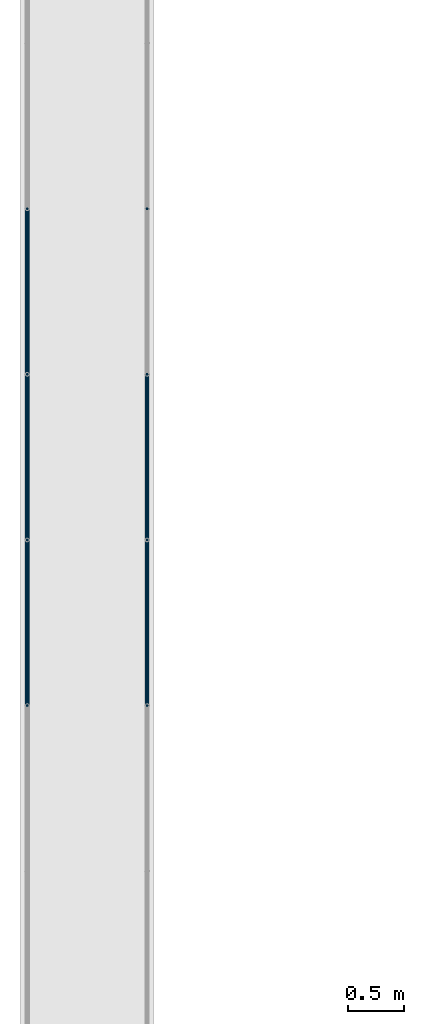
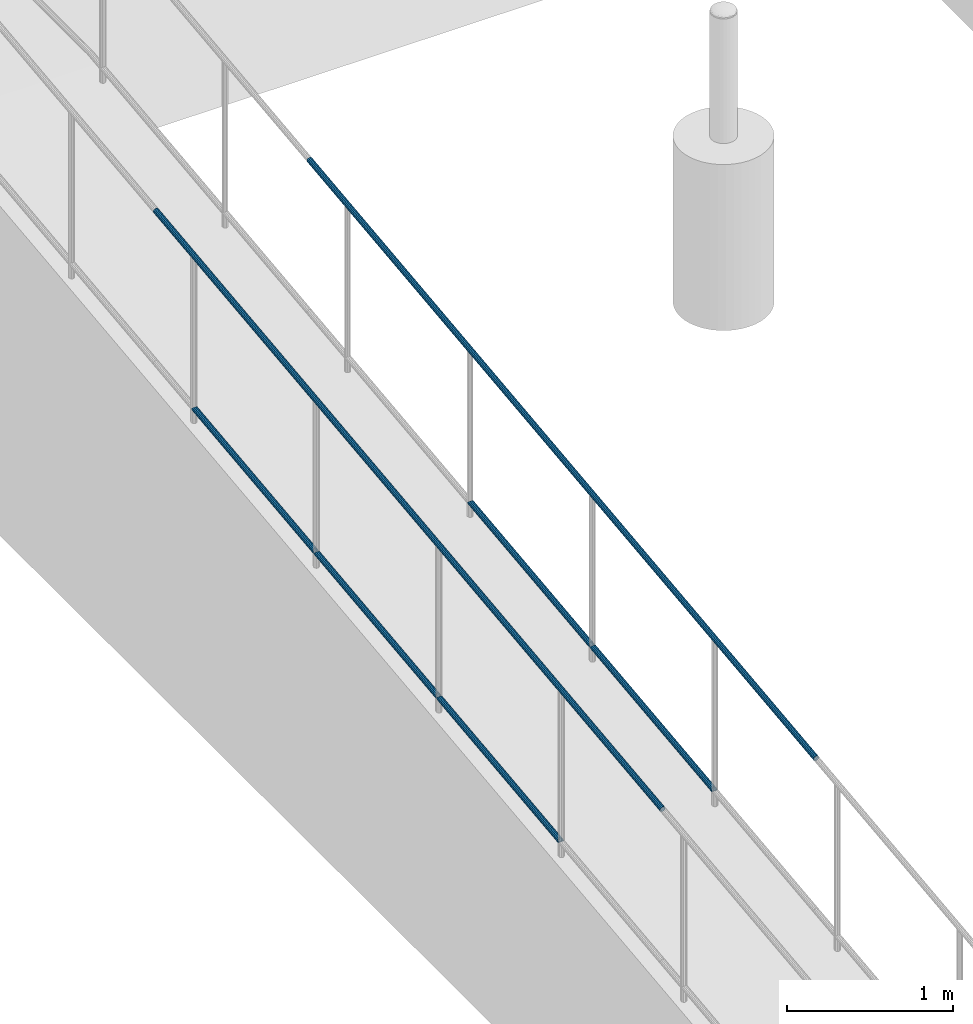
# One storey, part 1042 of 1763: 7 beams, 2 elements without a shape of their own.
"""IFC2X3 building model written with IfcOpenShell, lengths in millimetres."""

from ifc_helpers import new_model, si_unit, frame, origin_with_axes, place, context, subcontext, project, spatial, faceted_brep, material, type_object, element, aggregate, save


model = new_model("IFC2X3")

# Units and contexts
model_context = context("Model", 3, precision=1e-05, world=origin_with_axes())
body_context = subcontext(model_context, "Body", "Model", "MODEL_VIEW")
ifc_project = project(units=[si_unit("LENGTHUNIT", "METRE", prefix="MILLI"), si_unit("AREAUNIT", "SQUARE_METRE"), si_unit("VOLUMEUNIT", "CUBIC_METRE"), si_unit("MASSUNIT", "GRAM", prefix="KILO"), si_unit("TIMEUNIT", "SECOND"), si_unit("PLANEANGLEUNIT", "RADIAN"), si_unit("SOLIDANGLEUNIT", "STERADIAN"), si_unit("THERMODYNAMICTEMPERATUREUNIT", "DEGREE_CELSIUS"), si_unit("LUMINOUSINTENSITYUNIT", "LUMEN")], contexts=[model_context])

# Site, building, storey
site_placement = place(None, origin_with_axes())
site = spatial("IfcSite", under=ifc_project, at=site_placement, CompositionType="ELEMENT")
building_placement = place(site_placement, origin_with_axes())
building = spatial("IfcBuilding", under=site, at=building_placement, Name="Undefined", CompositionType="ELEMENT")
storey_placement = place(building_placement, origin_with_axes())
storey = spatial("IfcBuildingStorey", under=building, at=storey_placement, Name="Undefined", CompositionType="ELEMENT", Elevation=0.0)

# Assembly, beams
assembly_1_placement = place(storey_placement, origin_with_axes())
assembly_1 = element("IfcElementAssembly", 1, at=assembly_1_placement, inside=storey, Name="GUARDRAIL", AssemblyPlace="NOTDEFINED", PredefinedType="RIGID_FRAME")
ifc_material = material(Name="STEEL/A513")
beam_type = type_object("IfcBeamType", PredefinedType="NOTDEFINED")
beam_1_placement = place(assembly_1_placement, frame((-97200.6527017878, 1949.23787684902, 5506.99410694077), z_axis=(0.0, -0.114062593029902, 0.993473565260443), x_axis=(0.0, 0.993473565260443, 0.114062593029902)))
beam_1 = element("IfcBeam", 2, at=beam_1_placement, type_object=beam_type, material=ifc_material, Name="GUARDRAIL", context=body_context, shape_type="Brep", body=[
    faceted_brep([(1468.16675315117, -9.52499999999418, 16.4977839425374), (1467.58910193435, -9.52499999999418, 11.4667123803993), (1467.30386676072, -7.68349999999919, 13.3082123803997), (1465.46793646955, 0.0, 15.3670000004431), (1465.89080650931, 0.0, 19.0500000004431), (1467.30386676072, 7.68349999999919, 13.3082123803997), (1467.58910193435, 9.52499999999418, 11.4667123803993), (1468.16675315117, 9.52499999999418, 16.4977839425374), (1482.87870351455, 19.0500000000029, 4.47471393272281e-10), (1474.38475501203, 16.4977839420899, 9.52500000044529), (1472.19749618567, 16.4977839420899, -9.52499999955671), (1470.96279339167, 13.3082123799541, 7.68350000044484), (1472.15291256472, 15.3669999999984, 4.43833414465189e-10), (1469.19840460508, 13.3082123799541, -7.68349999955717), (1464.95596095143, 9.52499999999418, -11.4667123795143), (1464.37830973461, 9.52499999999418, -16.4977839416533), (1464.24785573805, 7.68349999999919, -13.3082123795139), (1461.93915889636, 0.0, -15.3669999995591), (1461.5162888566, 0.0, -19.04999999956), (1464.95596095143, -9.52499999999418, -11.4667123795143), (1464.37830973461, -9.52499999999418, -16.4977839416533), (1464.24785573805, -7.68349999999919, -13.3082123795139), (1482.87870351475, -19.0500000000029, 4.2564352042973e-10), (1472.19749618567, -16.4977839420899, -9.52499999955671), (1474.38475501203, -16.4977839420899, 9.52500000044529), (1469.19840460508, -13.3082123799541, -7.68349999955717), (1472.15291256472, -15.3669999999984, 4.43833414465189e-10), (1470.96279339167, -13.3082123799541, 7.68350000044484), (8.49524500772077, -16.4977839420899, -9.52499999999782), (14.7132496349991, -9.52499999999418, -16.4977839420899), (0.00129272617550669, 19.0500000000029, 0.0), (8.49524500772077, 16.4977839420899, -9.52499999999782), (10.6824953029745, 16.4977839420899, 9.52500000000418), (18.5016782752491, 9.52499999999418, 16.4977839421008), (21.3636978799404, 0.0, 19.0500000000075), (14.7132496349991, 9.52499999999418, -16.4977839420899), (16.989197289432, 0.0, -19.0499999999956), (17.4120656798477, 0.0, -15.3669999999956), (15.2908985987647, -9.52499999999418, -11.4667123799509), (15.5761345719984, -7.68349999999919, -13.3082123799513), (15.5761345719984, 7.68349999999919, -13.3082123799513), (15.2908985987647, 9.52499999999418, -11.4667123799509), (11.9172056406151, 13.3082123799541, -7.68349999999737), (10.7270831318519, 15.3669999999984, 4.54747350886464e-12), (13.6815875454467, 13.3082123799541, 7.68350000000555), (17.9240293114835, 9.52499999999418, 11.4667123799618), (18.6321336751216, 7.68349999999919, 13.3082123799622), (20.9408294895247, 0.0, 15.3670000000075), (18.6321336751212, -7.68349999999919, 13.3082123799622), (17.9240293114835, -9.52499999999418, 11.4667123799618), (18.5016782752491, -9.52499999999418, 16.4977839421008), (10.6824953029745, -16.4977839420899, 9.52500000000418), (0.00129272617550669, -19.0500000000029, 0.0), (13.6815875454458, -13.3082123799541, 7.68350000000464), (10.7270831318501, -15.3669999999984, 3.63797880709171e-12), (11.9172056406137, -13.3082123799541, -7.68349999999646)], [[[0, 1, 2, 3, 4]], [[4, 3, 5, 6, 7]], [[8, 9, 10]], [[7, 6, 11, 12, 13, 14, 15, 10, 9]], [[16, 17, 18, 15, 14]], [[19, 20, 18, 17, 21]], [[22, 23, 24]], [[24, 23, 20, 19, 25, 26, 27, 1, 0]], [[28, 29, 20, 23]], [[30, 31, 32]], [[33, 34, 4, 7]], [[32, 33, 7, 9]], [[30, 32, 9, 8]], [[31, 30, 8, 10]], [[35, 31, 10, 15]], [[36, 35, 15, 18]], [[29, 36, 18, 20]], [[37, 36, 29, 38, 39]], [[40, 41, 35, 36, 37]], [[32, 31, 35, 41, 42, 43, 44, 45, 33]], [[33, 45, 46, 47, 34]], [[34, 47, 48, 49, 50]], [[34, 50, 0, 4]], [[50, 51, 24, 0]], [[51, 52, 22, 24]], [[52, 28, 23, 22]], [[51, 28, 52]], [[50, 49, 53, 54, 55, 38, 29, 28, 51]], [[55, 54, 26, 25]], [[21, 39, 38, 55, 25, 19]], [[37, 39, 21, 17]], [[40, 37, 17, 16]], [[42, 41, 40, 16, 14, 13]], [[43, 42, 13, 12]], [[44, 43, 12, 11]], [[5, 46, 45, 44, 11, 6]], [[47, 46, 5, 3]], [[48, 47, 3, 2]], [[53, 49, 48, 2, 1, 27]], [[54, 53, 27, 26]]]),
])
beam_2_placement = place(assembly_1_placement, frame((-97200.6527017878, 476.037883341376, 5337.85320859481), z_axis=(0.0, -0.114062593029902, 0.993473565260443), x_axis=(0.0, 0.993473565260443, 0.114062593029902)))
beam_2 = element("IfcBeam", 3, at=beam_2_placement, type_object=beam_type, material=ifc_material, Name="GUARDRAIL", context=body_context, shape_type="Brep", body=[
    faceted_brep([(1468.16723516158, -9.52499999999418, 16.4977839425464), (1467.58958619782, -9.52499999999418, 11.4667123804093), (1467.3043502247, -7.68349999999919, 13.3082123804079), (1465.46841911673, 0.0, 15.3670000004531), (1465.89128750715, 0.0, 19.0500000004522), (1467.3043502247, 7.68349999999919, 13.3082123804079), (1467.58958619782, 9.52499999999418, 11.4667123804093), (1468.16723516158, 9.52499999999418, 16.4977839425464), (1482.87919207074, 19.0500000000029, 4.57475834991783e-10), (1474.38523978886, 16.4977839420899, 9.52500000045529), (1472.19798949361, 16.4977839420899, -9.52499999954671), (1470.96327915608, 13.3082123799541, 7.68350000045393), (1472.15340166484, 15.3669999999984, 4.53837856184691e-10), (1469.19889725125, 13.3082123799541, -7.68349999954717), (1464.9564554851, 9.52499999999418, -11.4667123795043), (1464.37880652133, 9.52499999999418, -16.4977839416424), (1464.24835112158, 7.68349999999919, -13.3082123795048), (1461.93965530706, 0.0, -15.36699999955), (1461.51678691664, 0.0, -19.04999999955), (1464.9564554851, -9.52499999999418, -11.4667123795043), (1464.37880652133, -9.52499999999418, -16.4977839416424), (1464.24835112157, -7.68349999999919, -13.3082123795048), (1482.87919207057, -19.0500000000029, 4.76575223729014e-10), (1472.19798949361, -16.4977839420899, -9.52499999954671), (1474.38523978886, -16.4977839420899, 9.52500000045529), (1469.19889725125, -13.3082123799541, -7.68349999954717), (1472.15340166484, -15.3669999999984, 4.53837856184691e-10), (1470.96327915608, -13.3082123799541, 7.68350000045393), (8.49463121237, -16.4977839420899, -9.52499999999782), (14.7126324911599, -9.52499999999418, -16.4977839420899), (0.00068350478454704, 19.0500000000029, 0.0), (8.49463121237, 16.4977839420899, -9.52499999999782), (10.6818918337324, 16.4977839420899, 9.52500000000418), (18.5010790167537, 9.52499999999418, 16.4977839421008), (21.3631001626848, 0.0, 19.0500000000075), (14.7126324911599, 9.52499999999418, -16.4977839420899), (16.9885789199607, 0.0, -19.0499999999956), (17.4114493067575, 0.0, -15.3669999999956), (15.2902841820321, -9.52499999999418, -11.4667123799509), (15.575519187561, -7.68349999999919, -13.3082123799513), (15.575519187561, 7.68349999999919, -13.3082123799513), (15.2902841820321, 9.52499999999418, -11.4667123799509), (11.9165930406441, 13.3082123799541, -7.68349999999646), (10.7264745694495, 15.3669999999984, 4.54747350886464e-12), (13.6809832752053, 13.3082123799541, 7.68350000000555), (17.923427325881, 9.52499999999418, 11.4667123799609), (18.631532718199, 7.68349999999919, 13.3082123799622), (20.9402297758882, 0.0, 15.3670000000075), (18.631532718199, -7.68349999999919, 13.3082123799622), (17.923427325881, -9.52499999999418, 11.4667123799609), (18.5010790167537, -9.52499999999418, 16.4977839421008), (10.6818918337324, -16.4977839420899, 9.52500000000418), (0.00068350478454704, -19.0500000000029, 0.0), (13.6809832752053, -13.3082123799541, 7.68350000000555), (10.7264745694495, -15.3669999999984, 4.54747350886464e-12), (11.9165930406441, -13.3082123799541, -7.68349999999646)], [[[0, 1, 2, 3, 4]], [[4, 3, 5, 6, 7]], [[8, 9, 10]], [[7, 6, 11, 12, 13, 14, 15, 10, 9]], [[16, 17, 18, 15, 14]], [[19, 20, 18, 17, 21]], [[22, 23, 24]], [[24, 23, 20, 19, 25, 26, 27, 1, 0]], [[28, 29, 20, 23]], [[30, 31, 32]], [[33, 34, 4, 7]], [[32, 33, 7, 9]], [[30, 32, 9, 8]], [[31, 30, 8, 10]], [[35, 31, 10, 15]], [[36, 35, 15, 18]], [[29, 36, 18, 20]], [[37, 36, 29, 38, 39]], [[40, 41, 35, 36, 37]], [[32, 31, 35, 41, 42, 43, 44, 45, 33]], [[33, 45, 46, 47, 34]], [[34, 47, 48, 49, 50]], [[34, 50, 0, 4]], [[50, 51, 24, 0]], [[51, 52, 22, 24]], [[52, 28, 23, 22]], [[51, 28, 52]], [[50, 49, 53, 54, 55, 38, 29, 28, 51]], [[55, 54, 26, 25]], [[21, 39, 38, 55, 25, 19]], [[37, 39, 21, 17]], [[40, 37, 17, 16]], [[42, 41, 40, 16, 14, 13]], [[43, 42, 13, 12]], [[44, 43, 12, 11]], [[5, 46, 45, 44, 11, 6]], [[47, 46, 5, 3]], [[48, 47, 3, 2]], [[53, 49, 48, 2, 1, 27]], [[54, 53, 27, 26]]]),
])
beam_3_placement = place(assembly_1_placement, frame((-97200.6527017878, -997.16211813846, 5168.71230933354), z_axis=(0.0, -0.114062593029902, 0.993473565260443), x_axis=(0.0, 0.993473565260443, 0.114062593029902)))
beam_3 = element("IfcBeam", 4, at=beam_3_placement, type_object=beam_type, material=ifc_material, Name="GUARDRAIL", context=body_context, shape_type="Brep", body=[
    faceted_brep([(1468.16665642951, -9.52499999999418, 16.4977839425555), (1467.58900470802, -9.52499999999418, 11.4667123804174), (1467.30376971339, -7.68349999999919, 13.3082123804179), (1465.46783960526, 0.0, 15.3670000004613), (1465.89071001447, 0.0, 19.0500000004622), (1467.3037697134, 7.68349999999919, 13.308212380417), (1467.58900470802, 9.52499999999418, 11.4667123804174), (1468.16665642951, 9.52499999999418, 16.4977839425555), (1482.87860532686, 19.0500000000029, 4.66570782009512e-10), (1474.38465767071, 16.4977839420899, 9.52500000046439), (1472.19739693342, 16.4977839420899, -9.52499999953761), (1470.96269582906, 13.3082123799541, 7.68350000046303), (1472.15281425492, 15.3669999999984, 4.6293280320242e-10), (1469.19830550098, 13.3082123799541, -7.68349999953807), (1464.95586142462, 9.52499999999418, -11.4667123794952), (1464.37820970313, 9.52499999999418, -16.4977839416342), (1464.24775602078, 7.68349999999919, -13.3082123794957), (1461.9390589491, 0.0, -15.3669999995409), (1461.51618853989, 0.0, -19.0499999995409), (1464.95586142462, -9.52499999999418, -11.4667123794952), (1464.37820970313, -9.52499999999418, -16.4977839416342), (1464.24775602078, -7.68349999999919, -13.3082123794948), (1482.87860532695, -19.0500000000029, 4.55656845588237e-10), (1472.19739693342, -16.4977839420899, -9.52499999953761), (1474.38465767071, -16.4977839420899, 9.52500000046439), (1469.19830550097, -13.3082123799541, -7.68349999953807), (1472.15281425491, -15.3669999999984, 4.6293280320242e-10), (1470.96269582905, -13.3082123799541, 7.68350000046303), (8.49463121237, -16.4977839420899, -9.52499999999782), (14.7126324911599, -9.52499999999418, -16.4977839420899), (0.00068350478454704, 19.0500000000029, 0.0), (8.49463121237, 16.4977839420899, -9.52499999999782), (10.6818918337324, 16.4977839420899, 9.52500000000418), (18.5010790167537, 9.52499999999418, 16.4977839421008), (21.3631001626848, 0.0, 19.0500000000075), (14.7126324911599, 9.52499999999418, -16.4977839420899), (16.9885789199607, 0.0, -19.0499999999956), (17.4114493067575, 0.0, -15.3669999999956), (15.2902841820321, -9.52499999999418, -11.4667123799509), (15.575519187561, -7.68349999999919, -13.3082123799513), (15.575519187561, 7.68349999999919, -13.3082123799513), (15.2902841820321, 9.52499999999418, -11.4667123799509), (11.9165930406441, 13.3082123799541, -7.68349999999646), (10.7264745694495, 15.3669999999984, 4.54747350886464e-12), (13.6809832752053, 13.3082123799541, 7.68350000000555), (17.923427325881, 9.52499999999418, 11.4667123799609), (18.631532718199, 7.68349999999919, 13.3082123799622), (20.9402297758882, 0.0, 15.3670000000075), (18.631532718199, -7.68349999999919, 13.3082123799622), (17.923427325881, -9.52499999999418, 11.4667123799609), (18.5010790167537, -9.52499999999418, 16.4977839421008), (10.6818918337324, -16.4977839420899, 9.52500000000418), (0.00068350478454704, -19.0500000000029, 0.0), (13.6809832752053, -13.3082123799541, 7.68350000000555), (10.7264745694495, -15.3669999999984, 4.54747350886464e-12), (11.9165930406441, -13.3082123799541, -7.68349999999646)], [[[0, 1, 2, 3, 4]], [[4, 3, 5, 6, 7]], [[8, 9, 10]], [[7, 6, 11, 12, 13, 14, 15, 10, 9]], [[16, 17, 18, 15, 14]], [[19, 20, 18, 17, 21]], [[22, 23, 24]], [[24, 23, 20, 19, 25, 26, 27, 1, 0]], [[28, 29, 20, 23]], [[30, 31, 32]], [[33, 34, 4, 7]], [[32, 33, 7, 9]], [[30, 32, 9, 8]], [[31, 30, 8, 10]], [[35, 31, 10, 15]], [[36, 35, 15, 18]], [[29, 36, 18, 20]], [[37, 36, 29, 38, 39]], [[40, 41, 35, 36, 37]], [[32, 31, 35, 41, 42, 43, 44, 45, 33]], [[33, 45, 46, 47, 34]], [[34, 47, 48, 49, 50]], [[34, 50, 0, 4]], [[50, 51, 24, 0]], [[51, 52, 22, 24]], [[52, 28, 23, 22]], [[51, 28, 52]], [[50, 49, 53, 54, 55, 38, 29, 28, 51]], [[55, 54, 26, 25]], [[21, 39, 38, 55, 25, 19]], [[37, 39, 21, 17]], [[40, 37, 17, 16]], [[42, 41, 40, 16, 14, 13]], [[43, 42, 13, 12]], [[44, 43, 12, 11]], [[5, 46, 45, 44, 11, 6]], [[47, 46, 5, 3]], [[48, 47, 3, 2]], [[53, 49, 48, 2, 1, 27]], [[54, 53, 27, 26]]]),
])
beam_4_placement = place(assembly_1_placement, frame((-97200.6527017878, -2216.29390356327, 6146.34146606881), z_axis=(-1.0, 0.0, 0.0), x_axis=(0.0, 0.993473565260443, 0.114062593029902)))
beam_4 = element("IfcBeam", 5, at=beam_4_placement, type_object=beam_type, material=ifc_material, Name="GUARDRAIL", context=body_context, shape_type="Brep", body=[
    faceted_brep([(4.71409293822944e-08, -15.3669999999984, 0.0), (-1.81898940354586e-12, -13.3082123799541, 7.68349999999919), (6136.046507088, -13.3082123818076, 7.68349999999919), (6136.046507088, -15.3670000018528, 0.0), (-3.63797880709171e-12, -7.68349999999919, 13.3082123799531), (6136.046507088, -7.68350000185274, 13.3082123799541), (-1.81898940354586e-12, 0.0, 15.3669999999966), (6136.046507088, -1.85082171810791e-09, 15.3669999999984), (-3.63797880709171e-12, 7.68349999999919, 13.3082123799531), (6136.046507088, 7.68349999814836, 13.3082123799541), (-1.81898940354586e-12, 13.3082123799541, 7.68349999999919), (6136.046507088, 13.3082123781051, 7.68349999999919), (4.71409293822944e-08, 15.3669999999984, 0.0), (6136.046507088, 15.3669999981494, 0.0), (3.63797880709171e-12, 13.3082123799541, -7.68349999999737), (6136.046507088, 13.3082123781051, -7.68349999999919), (3.63797880709171e-12, 7.68349999999919, -13.3082123799522), (6136.046507088, 7.68349999814836, -13.3082123799541), (3.63797880709171e-12, 0.0, -15.3669999999956), (6136.046507088, -1.85082171810791e-09, -15.3669999999984), (3.63797880709171e-12, -7.68349999999919, -13.3082123799522), (6136.046507088, -7.68350000185274, -13.3082123799541), (3.63797880709171e-12, -13.3082123799541, -7.68349999999737), (6136.046507088, -13.3082123818076, -7.68349999999919), (0.0, -19.0500000000029, 0.0), (0.0, -16.4977839420899, -9.52500000000146), (6136.046507088, -16.4977839439462, -9.52499999999418), (6136.046507088, -19.0500000018519, 0.0), (0.0, -9.52499999999418, -16.4977839420935), (6136.046507088, -9.52500000185228, -16.4977839420899), (1.45519152283669e-11, 1.81898940354586e-12, -19.0499999999993), (6136.046507088, -1.85082171810791e-09, -19.0500000000029), (0.0, 9.52499999999418, -16.4977839420935), (6136.046507088, 9.5249999981479, -16.4977839420899), (0.0, 16.4977839420899, -9.52500000000146), (6136.046507088, 16.4977839402427, -9.52499999999418), (0.0, 19.0500000000029, 0.0), (6136.046507088, 19.0499999981485, 0.0), (0.0, 16.4977839420899, 9.52500000000146), (6136.046507088, 16.4977839402427, 9.52499999999418), (0.0, 9.52499999999418, 16.4977839420935), (6136.046507088, 9.5249999981479, 16.4977839420899), (1.45519152283669e-11, 1.81898940354586e-12, 19.0499999999993), (6136.046507088, -1.85082171810791e-09, 19.0500000000029), (0.0, -9.52499999999418, 16.4977839420935), (6136.046507088, -9.52500000185228, 16.4977839420899), (0.0, -16.4977839420899, 9.52500000000146), (6136.046507088, -16.4977839439462, 9.52499999999418)], [[[0, 1, 2, 3]], [[1, 4, 5, 2]], [[4, 6, 7, 5]], [[6, 8, 9, 7]], [[8, 10, 11, 9]], [[10, 12, 13, 11]], [[12, 14, 15, 13]], [[14, 16, 17, 15]], [[16, 18, 19, 17]], [[18, 20, 21, 19]], [[20, 22, 23, 21]], [[22, 0, 3, 23]], [[24, 25, 26, 27]], [[25, 28, 29, 26]], [[28, 30, 31, 29]], [[30, 32, 33, 31]], [[32, 34, 35, 33]], [[34, 36, 37, 35]], [[36, 38, 39, 37]], [[38, 40, 41, 39]], [[40, 42, 43, 41]], [[42, 44, 45, 43]], [[44, 46, 47, 45]], [[46, 24, 27, 47]], [[29, 31, 33, 35, 37, 39, 41, 43, 45, 47, 27, 26], [5, 7, 9, 11, 13, 15, 17, 19, 21, 23, 3, 2]], [[46, 44, 42, 40, 38, 36, 34, 32, 30, 28, 25, 24], [22, 20, 18, 16, 14, 12, 10, 8, 6, 4, 1, 0]]]),
])
aggregate(assembly_1, [beam_1, beam_2, beam_3, beam_4])

assembly_2_placement = place(storey_placement, origin_with_axes())
assembly_2 = element("IfcElementAssembly", 6, at=assembly_2_placement, inside=storey, Name="GUARDRAIL", AssemblyPlace="NOTDEFINED", PredefinedType="RIGID_FRAME")
beam_5_placement = place(assembly_2_placement, frame((-96133.8527017878, -2216.29390356327, 6146.34146606881), z_axis=(-1.0, 0.0, 0.0), x_axis=(0.0, 0.993473565260443, 0.114062593029902)))
beam_5 = element("IfcBeam", 7, at=beam_5_placement, type_object=beam_type, material=ifc_material, Name="GUARDRAIL", context=body_context, shape_type="Brep", body=[
    faceted_brep([(4.71409293822944e-08, -15.3669999999984, 0.0), (-1.81898940354586e-12, -13.3082123799541, 7.68349999999919), (6136.046507088, -13.3082123818076, 7.68349999999919), (6136.046507088, -15.3670000018528, 0.0), (-3.63797880709171e-12, -7.68349999999919, 13.3082123799531), (6136.046507088, -7.68350000185274, 13.3082123799541), (-1.81898940354586e-12, 0.0, 15.3669999999966), (6136.046507088, -1.85082171810791e-09, 15.3669999999984), (-3.63797880709171e-12, 7.68349999999919, 13.3082123799531), (6136.046507088, 7.68349999814836, 13.3082123799541), (-1.81898940354586e-12, 13.3082123799541, 7.68349999999919), (6136.046507088, 13.3082123781051, 7.68349999999919), (4.71409293822944e-08, 15.3669999999984, 0.0), (6136.046507088, 15.3669999981494, 0.0), (3.63797880709171e-12, 13.3082123799541, -7.68349999999737), (6136.046507088, 13.3082123781051, -7.68349999999919), (3.63797880709171e-12, 7.68349999999919, -13.3082123799522), (6136.046507088, 7.68349999814836, -13.3082123799541), (3.63797880709171e-12, 0.0, -15.3669999999956), (6136.046507088, -1.85082171810791e-09, -15.3669999999984), (3.63797880709171e-12, -7.68349999999919, -13.3082123799522), (6136.046507088, -7.68350000185274, -13.3082123799541), (3.63797880709171e-12, -13.3082123799541, -7.68349999999737), (6136.046507088, -13.3082123818076, -7.68349999999919), (0.0, -19.0500000000029, 0.0), (0.0, -16.4977839420899, -9.52500000000146), (6136.046507088, -16.4977839439462, -9.52499999999418), (6136.046507088, -19.0500000018519, 0.0), (0.0, -9.52499999999418, -16.4977839420935), (6136.046507088, -9.52500000185228, -16.4977839420899), (1.45519152283669e-11, 1.81898940354586e-12, -19.0499999999993), (6136.046507088, -1.85082171810791e-09, -19.0500000000029), (0.0, 9.52499999999418, -16.4977839420935), (6136.046507088, 9.5249999981479, -16.4977839420899), (0.0, 16.4977839420899, -9.52500000000146), (6136.046507088, 16.4977839402427, -9.52499999999418), (0.0, 19.0500000000029, 0.0), (6136.046507088, 19.0499999981485, 0.0), (0.0, 16.4977839420899, 9.52500000000146), (6136.046507088, 16.4977839402427, 9.52499999999418), (0.0, 9.52499999999418, 16.4977839420935), (6136.046507088, 9.5249999981479, 16.4977839420899), (1.45519152283669e-11, 1.81898940354586e-12, 19.0499999999993), (6136.046507088, -1.85082171810791e-09, 19.0500000000029), (0.0, -9.52499999999418, 16.4977839420935), (6136.046507088, -9.52500000185228, 16.4977839420899), (0.0, -16.4977839420899, 9.52500000000146), (6136.046507088, -16.4977839439462, 9.52499999999418)], [[[0, 1, 2, 3]], [[1, 4, 5, 2]], [[4, 6, 7, 5]], [[6, 8, 9, 7]], [[8, 10, 11, 9]], [[10, 12, 13, 11]], [[12, 14, 15, 13]], [[14, 16, 17, 15]], [[16, 18, 19, 17]], [[18, 20, 21, 19]], [[20, 22, 23, 21]], [[22, 0, 3, 23]], [[24, 25, 26, 27]], [[25, 28, 29, 26]], [[28, 30, 31, 29]], [[30, 32, 33, 31]], [[32, 34, 35, 33]], [[34, 36, 37, 35]], [[36, 38, 39, 37]], [[38, 40, 41, 39]], [[40, 42, 43, 41]], [[42, 44, 45, 43]], [[44, 46, 47, 45]], [[46, 24, 27, 47]], [[29, 31, 33, 35, 37, 39, 41, 43, 45, 47, 27, 26], [5, 7, 9, 11, 13, 15, 17, 19, 21, 23, 3, 2]], [[46, 44, 42, 40, 38, 36, 34, 32, 30, 28, 25, 24], [22, 20, 18, 16, 14, 12, 10, 8, 6, 4, 1, 0]]]),
])
beam_6_placement = place(assembly_2_placement, frame((-96133.8527017878, 476.037883341376, 5337.85320859481), z_axis=(0.0, -0.114062593029902, 0.993473565260443), x_axis=(0.0, 0.993473565260443, 0.114062593029902)))
beam_6 = element("IfcBeam", 8, at=beam_6_placement, type_object=beam_type, material=ifc_material, Name="GUARDRAIL", context=body_context, shape_type="Brep", body=[
    faceted_brep([(1468.16723516158, -9.52499999999418, 16.4977839425464), (1467.58958619782, -9.52499999999418, 11.4667123804093), (1467.3043502247, -7.68349999999919, 13.3082123804079), (1465.46841911673, 0.0, 15.3670000004531), (1465.89128750715, 0.0, 19.0500000004522), (1467.3043502247, 7.68349999999919, 13.3082123804079), (1467.58958619782, 9.52499999999418, 11.4667123804093), (1468.16723516158, 9.52499999999418, 16.4977839425464), (1482.87919207074, 19.0500000000029, 4.57475834991783e-10), (1474.38523978886, 16.4977839420899, 9.52500000045529), (1472.19798949361, 16.4977839420899, -9.52499999954671), (1470.96327915608, 13.3082123799541, 7.68350000045393), (1472.15340166484, 15.3669999999984, 4.53837856184691e-10), (1469.19889725125, 13.3082123799541, -7.68349999954717), (1464.9564554851, 9.52499999999418, -11.4667123795043), (1464.37880652133, 9.52499999999418, -16.4977839416424), (1464.24835112158, 7.68349999999919, -13.3082123795048), (1461.93965530706, 0.0, -15.36699999955), (1461.51678691664, 0.0, -19.04999999955), (1464.9564554851, -9.52499999999418, -11.4667123795043), (1464.37880652133, -9.52499999999418, -16.4977839416424), (1464.24835112157, -7.68349999999919, -13.3082123795048), (1482.87919207057, -19.0500000000029, 4.76575223729014e-10), (1472.19798949361, -16.4977839420899, -9.52499999954671), (1474.38523978886, -16.4977839420899, 9.52500000045529), (1469.19889725125, -13.3082123799541, -7.68349999954717), (1472.15340166484, -15.3669999999984, 4.53837856184691e-10), (1470.96327915608, -13.3082123799541, 7.68350000045393), (8.49463121237, -16.4977839420899, -9.52499999999782), (14.7126324911599, -9.52499999999418, -16.4977839420899), (0.00068350478454704, 19.0500000000029, 0.0), (8.49463121237, 16.4977839420899, -9.52499999999782), (10.6818918337324, 16.4977839420899, 9.52500000000418), (18.5010790167537, 9.52499999999418, 16.4977839421008), (21.3631001626848, 0.0, 19.0500000000075), (14.7126324911599, 9.52499999999418, -16.4977839420899), (16.9885789199607, 0.0, -19.0499999999956), (17.4114493067575, 0.0, -15.3669999999956), (15.2902841820321, -9.52499999999418, -11.4667123799509), (15.575519187561, -7.68349999999919, -13.3082123799513), (15.575519187561, 7.68349999999919, -13.3082123799513), (15.2902841820321, 9.52499999999418, -11.4667123799509), (11.9165930406441, 13.3082123799541, -7.68349999999646), (10.7264745694495, 15.3669999999984, 4.54747350886464e-12), (13.6809832752053, 13.3082123799541, 7.68350000000555), (17.923427325881, 9.52499999999418, 11.4667123799609), (18.631532718199, 7.68349999999919, 13.3082123799622), (20.9402297758882, 0.0, 15.3670000000075), (18.631532718199, -7.68349999999919, 13.3082123799622), (17.923427325881, -9.52499999999418, 11.4667123799609), (18.5010790167537, -9.52499999999418, 16.4977839421008), (10.6818918337324, -16.4977839420899, 9.52500000000418), (0.00068350478454704, -19.0500000000029, 0.0), (13.6809832752053, -13.3082123799541, 7.68350000000555), (10.7264745694495, -15.3669999999984, 4.54747350886464e-12), (11.9165930406441, -13.3082123799541, -7.68349999999646)], [[[0, 1, 2, 3, 4]], [[4, 3, 5, 6, 7]], [[8, 9, 10]], [[7, 6, 11, 12, 13, 14, 15, 10, 9]], [[16, 17, 18, 15, 14]], [[19, 20, 18, 17, 21]], [[22, 23, 24]], [[24, 23, 20, 19, 25, 26, 27, 1, 0]], [[28, 29, 20, 23]], [[30, 31, 32]], [[33, 34, 4, 7]], [[32, 33, 7, 9]], [[30, 32, 9, 8]], [[31, 30, 8, 10]], [[35, 31, 10, 15]], [[36, 35, 15, 18]], [[29, 36, 18, 20]], [[37, 36, 29, 38, 39]], [[40, 41, 35, 36, 37]], [[32, 31, 35, 41, 42, 43, 44, 45, 33]], [[33, 45, 46, 47, 34]], [[34, 47, 48, 49, 50]], [[34, 50, 0, 4]], [[50, 51, 24, 0]], [[51, 52, 22, 24]], [[52, 28, 23, 22]], [[51, 28, 52]], [[50, 49, 53, 54, 55, 38, 29, 28, 51]], [[55, 54, 26, 25]], [[21, 39, 38, 55, 25, 19]], [[37, 39, 21, 17]], [[40, 37, 17, 16]], [[42, 41, 40, 16, 14, 13]], [[43, 42, 13, 12]], [[44, 43, 12, 11]], [[5, 46, 45, 44, 11, 6]], [[47, 46, 5, 3]], [[48, 47, 3, 2]], [[53, 49, 48, 2, 1, 27]], [[54, 53, 27, 26]]]),
])
beam_7_placement = place(assembly_2_placement, frame((-96133.8527017878, -997.16211813846, 5168.71230933354), z_axis=(0.0, -0.114062593029902, 0.993473565260443), x_axis=(0.0, 0.993473565260443, 0.114062593029902)))
beam_7 = element("IfcBeam", 9, at=beam_7_placement, type_object=beam_type, material=ifc_material, Name="GUARDRAIL", context=body_context, shape_type="Brep", body=[
    faceted_brep([(1468.16665642951, -9.52499999999418, 16.4977839425555), (1467.58900470802, -9.52499999999418, 11.4667123804174), (1467.30376971339, -7.68349999999919, 13.3082123804179), (1465.46783960526, 0.0, 15.3670000004613), (1465.89071001447, 0.0, 19.0500000004622), (1467.3037697134, 7.68349999999919, 13.308212380417), (1467.58900470802, 9.52499999999418, 11.4667123804174), (1468.16665642951, 9.52499999999418, 16.4977839425555), (1482.87860532686, 19.0500000000029, 4.66570782009512e-10), (1474.38465767071, 16.4977839420899, 9.52500000046439), (1472.19739693342, 16.4977839420899, -9.52499999953761), (1470.96269582906, 13.3082123799541, 7.68350000046303), (1472.15281425492, 15.3669999999984, 4.6293280320242e-10), (1469.19830550098, 13.3082123799541, -7.68349999953807), (1464.95586142462, 9.52499999999418, -11.4667123794952), (1464.37820970313, 9.52499999999418, -16.4977839416342), (1464.24775602078, 7.68349999999919, -13.3082123794957), (1461.9390589491, 0.0, -15.3669999995409), (1461.51618853989, 0.0, -19.0499999995409), (1464.95586142462, -9.52499999999418, -11.4667123794952), (1464.37820970313, -9.52499999999418, -16.4977839416342), (1464.24775602078, -7.68349999999919, -13.3082123794948), (1482.87860532695, -19.0500000000029, 4.55656845588237e-10), (1472.19739693342, -16.4977839420899, -9.52499999953761), (1474.38465767071, -16.4977839420899, 9.52500000046439), (1469.19830550097, -13.3082123799541, -7.68349999953807), (1472.15281425491, -15.3669999999984, 4.6293280320242e-10), (1470.96269582905, -13.3082123799541, 7.68350000046303), (8.49463121237, -16.4977839420899, -9.52499999999782), (14.7126324911599, -9.52499999999418, -16.4977839420899), (0.00068350478454704, 19.0500000000029, 0.0), (8.49463121237, 16.4977839420899, -9.52499999999782), (10.6818918337324, 16.4977839420899, 9.52500000000418), (18.5010790167537, 9.52499999999418, 16.4977839421008), (21.3631001626848, 0.0, 19.0500000000075), (14.7126324911599, 9.52499999999418, -16.4977839420899), (16.9885789199607, 0.0, -19.0499999999956), (17.4114493067575, 0.0, -15.3669999999956), (15.2902841820321, -9.52499999999418, -11.4667123799509), (15.575519187561, -7.68349999999919, -13.3082123799513), (15.575519187561, 7.68349999999919, -13.3082123799513), (15.2902841820321, 9.52499999999418, -11.4667123799509), (11.9165930406441, 13.3082123799541, -7.68349999999646), (10.7264745694495, 15.3669999999984, 4.54747350886464e-12), (13.6809832752053, 13.3082123799541, 7.68350000000555), (17.923427325881, 9.52499999999418, 11.4667123799609), (18.631532718199, 7.68349999999919, 13.3082123799622), (20.9402297758882, 0.0, 15.3670000000075), (18.631532718199, -7.68349999999919, 13.3082123799622), (17.923427325881, -9.52499999999418, 11.4667123799609), (18.5010790167537, -9.52499999999418, 16.4977839421008), (10.6818918337324, -16.4977839420899, 9.52500000000418), (0.00068350478454704, -19.0500000000029, 0.0), (13.6809832752053, -13.3082123799541, 7.68350000000555), (10.7264745694495, -15.3669999999984, 4.54747350886464e-12), (11.9165930406441, -13.3082123799541, -7.68349999999646)], [[[0, 1, 2, 3, 4]], [[4, 3, 5, 6, 7]], [[8, 9, 10]], [[7, 6, 11, 12, 13, 14, 15, 10, 9]], [[16, 17, 18, 15, 14]], [[19, 20, 18, 17, 21]], [[22, 23, 24]], [[24, 23, 20, 19, 25, 26, 27, 1, 0]], [[28, 29, 20, 23]], [[30, 31, 32]], [[33, 34, 4, 7]], [[32, 33, 7, 9]], [[30, 32, 9, 8]], [[31, 30, 8, 10]], [[35, 31, 10, 15]], [[36, 35, 15, 18]], [[29, 36, 18, 20]], [[37, 36, 29, 38, 39]], [[40, 41, 35, 36, 37]], [[32, 31, 35, 41, 42, 43, 44, 45, 33]], [[33, 45, 46, 47, 34]], [[34, 47, 48, 49, 50]], [[34, 50, 0, 4]], [[50, 51, 24, 0]], [[51, 52, 22, 24]], [[52, 28, 23, 22]], [[51, 28, 52]], [[50, 49, 53, 54, 55, 38, 29, 28, 51]], [[55, 54, 26, 25]], [[21, 39, 38, 55, 25, 19]], [[37, 39, 21, 17]], [[40, 37, 17, 16]], [[42, 41, 40, 16, 14, 13]], [[43, 42, 13, 12]], [[44, 43, 12, 11]], [[5, 46, 45, 44, 11, 6]], [[47, 46, 5, 3]], [[48, 47, 3, 2]], [[53, 49, 48, 2, 1, 27]], [[54, 53, 27, 26]]]),
])
aggregate(assembly_2, [beam_5, beam_6, beam_7])

save(model, "model.ifc")
